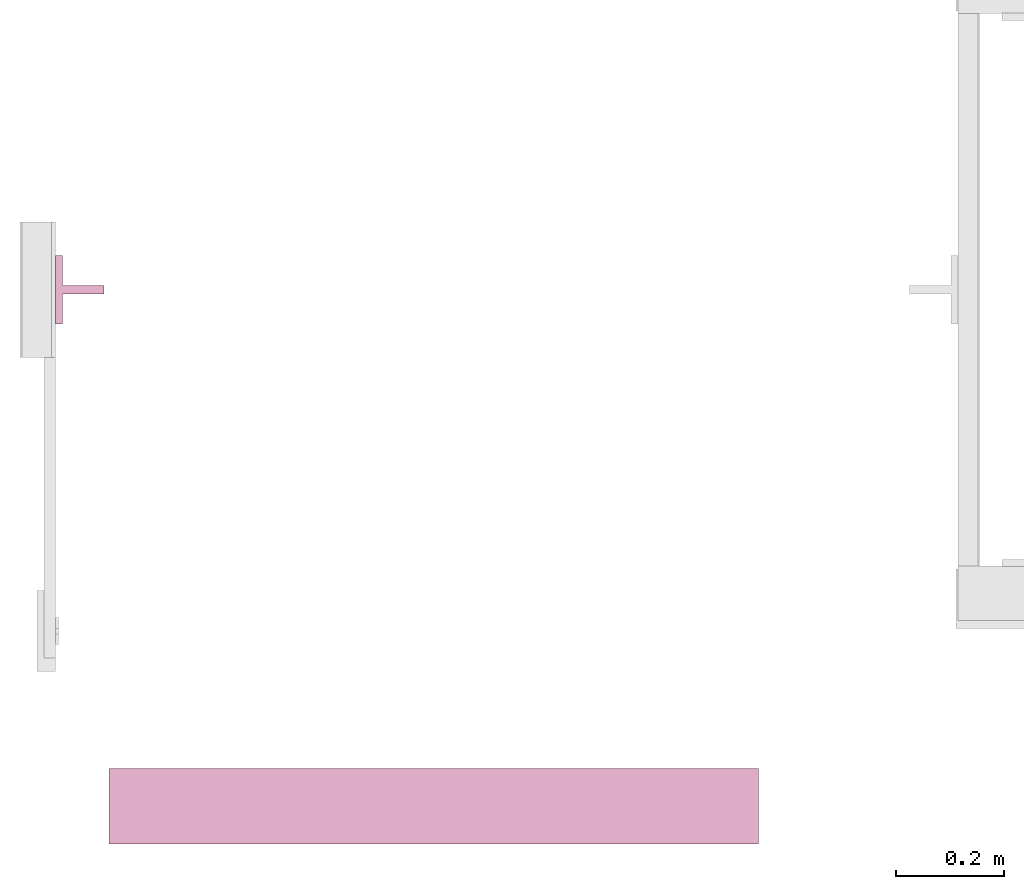
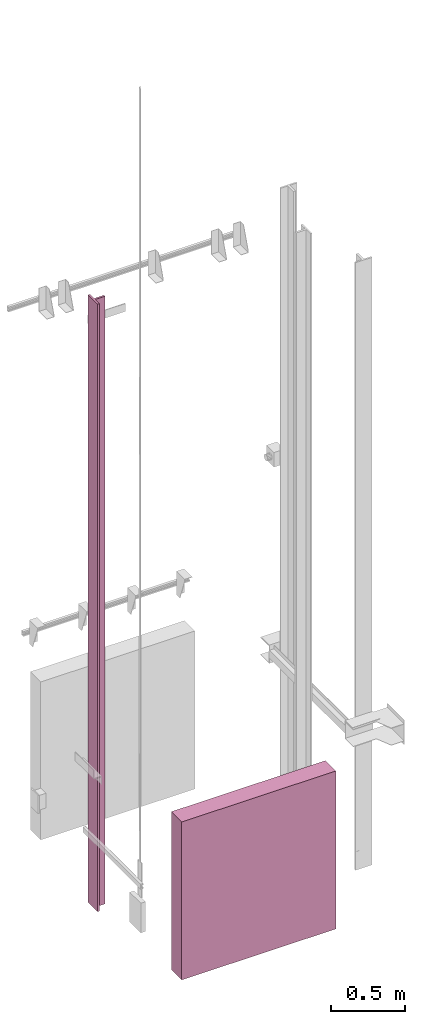
# One storey, part 3 of 5: 2 transport elements.
"""IFC4 building model written with IfcOpenShell, lengths in millimetres."""

from ifc_helpers import new_model, entity, si_unit, converted_unit, frame, origin_with_axes, place, context, subcontext, project, spatial, faceted_brep, element, save


model = new_model("IFC4")

# Units and contexts
context_of_model = context(None, 3, precision=0.01, world=origin_with_axes())
sub_context_1 = subcontext(context_of_model, None, None, "MODEL_VIEW")
sub_context_2 = subcontext(context_of_model, None, None, "MODEL_VIEW")
ifc_project = project(units=[converted_unit("PLANEANGLEUNIT", "degree", entity("IfcPlaneAngleMeasure", 0.017453292519943), si_unit("PLANEANGLEUNIT", "RADIAN"), dimensions=[0, 0, 0, 0, 0, 0, 0]), si_unit("LENGTHUNIT", "METRE", prefix="MILLI"), si_unit("MASSUNIT", "GRAM", prefix="KILO"), converted_unit("TIMEUNIT", "year", entity("IfcTimeMeasure", 31557600.0), si_unit("TIMEUNIT", "SECOND"), dimensions=[0, 0, 1, 0, 0, 0, 0]), si_unit("THERMODYNAMICTEMPERATUREUNIT", "DEGREE_CELSIUS"), si_unit("AREAUNIT", "SQUARE_METRE"), si_unit("FORCEUNIT", "NEWTON"), si_unit("VOLUMEUNIT", "CUBIC_METRE"), si_unit("PRESSUREUNIT", "PASCAL"), si_unit("SOLIDANGLEUNIT", "STERADIAN")], contexts=[context_of_model])

# Site, building, storey
site = spatial("IfcSite", under=ifc_project)
building = spatial("IfcBuilding", under=site, Name="Document")
placement = place(None, origin_with_axes())
storey_placement = place(placement, frame((0.0, 0.0, -24650.0), z_axis=(0.0, 0.0, 1.0), x_axis=(1.0, 0.0, 0.0)))
storey = spatial("IfcBuildingStorey", under=building, at=storey_placement, Name="P11", Elevation=-24650.0)

# Transport elements
transport_element_1_placement = place(storey_placement, frame((110.5, 1025.0, 763.0), z_axis=(-1.0, 0.0, 0.0), x_axis=(0.0, 0.0, -1.0)))
element("IfcTransportElement", 1, at=transport_element_1_placement, inside=storey, ObjectType="Guide Rail", PredefinedType="ELEVATOR", context=sub_context_1, shape_type="Brep", body=[
    faceted_brep([(-2500.0, 63.5, 44.5), (-2500.0, -63.5, 44.5), (2500.0, -63.5, 44.5), (2500.0, 63.5, 44.5), (2500.0, 7.94000244140625, 31.800003051757812), (-2500.0, 7.94000244140625, 31.800003051757812), (-2500.0, 63.5, 31.79998779296875), (2500.0, 63.5, 31.79998779296875), (2500.0, -63.5, 31.79998779296875), (-2500.0, -63.5, 31.79998779296875), (-2500.0, -7.93994140625, 31.79998779296875), (2500.0, -7.93994140625, 31.79998779296875), (2500.0, -7.93994140625, -44.5), (-2500.0, -7.93994140625, -44.5), (-2500.0, 7.94000244140625, -44.5), (2500.0, 7.94000244140625, -44.5)], [[[0, 1, 2, 3]], [[4, 5, 6, 7]], [[8, 9, 10, 11]], [[12, 13, 14, 15]], [[7, 6, 0, 3]], [[15, 14, 5, 4]], [[10, 13, 12, 11]], [[1, 9, 8, 2]], [[2, 8, 11, 12, 15, 4, 7, 3]], [[6, 5, 14, 13, 10, 9, 1, 0]]]),
    faceted_brep([(2347.5, -63.5, 45.0), (2347.5, 63.5, 45.0), (2347.5, 63.5, 44.0), (2347.5, -63.5, 44.0), (2500.0, -63.5, 45.0), (2500.0, -63.5, 44.0), (2500.0, 63.5, 44.0), (2500.0, 63.5, 45.0)], [[[0, 1, 2, 3]], [[4, 5, 6, 7]], [[0, 3, 5, 4]], [[3, 2, 6, 5]], [[2, 1, 7, 6]], [[1, 0, 4, 7]]]),
    faceted_brep([(-2500.0, -63.5, 45.0), (-2500.0, 63.5, 45.0), (-2500.0, 63.5, 44.0), (-2500.0, -63.5, 44.0), (-2347.5, -63.5, 45.0), (-2347.5, -63.5, 44.0), (-2347.5, 63.5, 44.0), (-2347.5, 63.5, 45.0)], [[[0, 1, 2, 3]], [[4, 5, 6, 7]], [[0, 3, 5, 4]], [[3, 2, 6, 5]], [[2, 1, 7, 6]], [[1, 0, 4, 7]]]),
])
transport_element_2_placement = place(storey_placement, frame((765.0, 70.0, -1750.0), z_axis=(0.0, 0.0, 1.0), x_axis=(1.0, 0.0, 0.0)))
element("IfcTransportElement", 2, at=transport_element_2_placement, inside=storey, PredefinedType="ELEVATOR", context=sub_context_2, shape_type="Brep", body=[
    faceted_brep([(-600.0, -70.0, 1300.0), (-600.0, 70.0, 1300.0), (-600.0, 70.0, 0.0), (-600.0, -70.0, 0.0), (600.0, -70.0, 1300.0), (600.0, -70.0, 0.0), (600.0, 70.0, 0.0), (600.0, 70.0, 1300.0)], [[[0, 1, 2, 3]], [[4, 5, 6, 7]], [[0, 3, 5, 4]], [[3, 2, 6, 5]], [[2, 1, 7, 6]], [[1, 0, 4, 7]]]),
])

save(model, "model.ifc")
